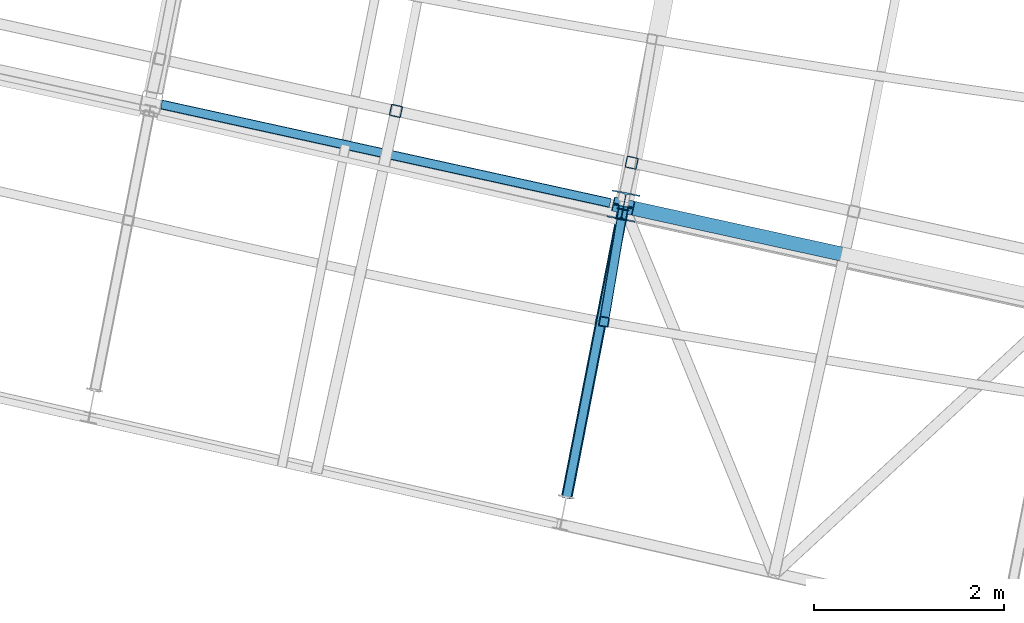
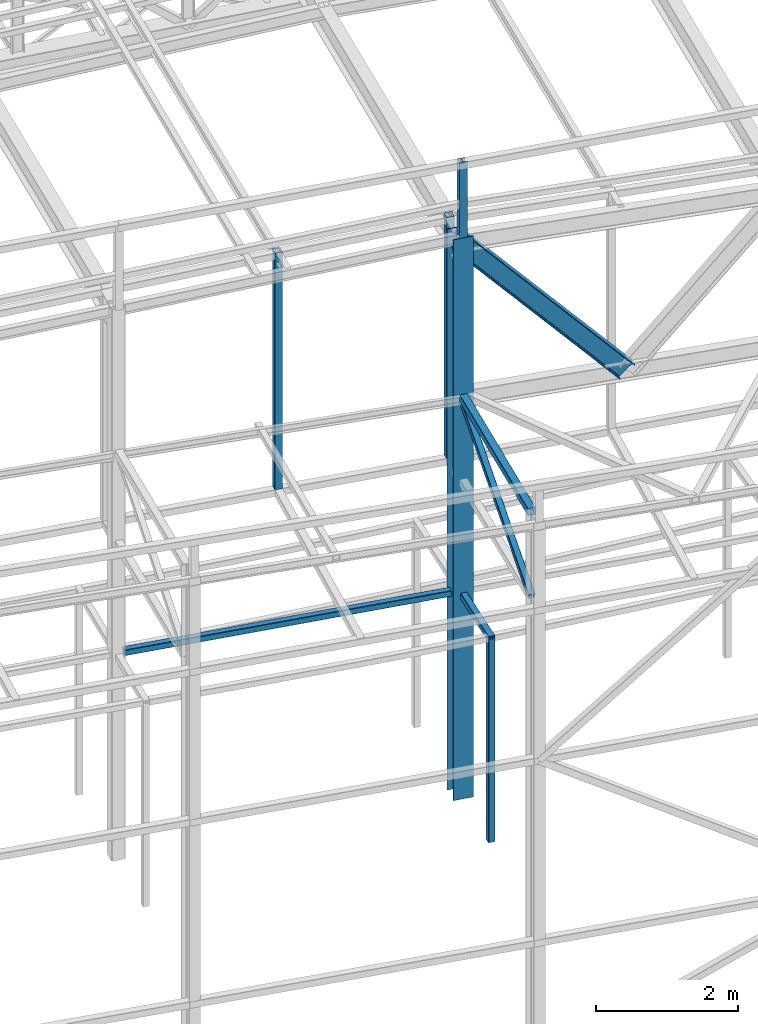
# One storey, part 30 of 215: 8 beams, 2 members, 10 elements without a shape of their own.
"""IFC2X3 building model written with IfcOpenShell, lengths in millimetres."""

from ifc_helpers import new_model, si_unit, frame, origin_with_axes, origin_2d_with_axis, place, context, subcontext, project, spatial, hollow_rectangle, i_section, extrude, clip, halfspace, material, type_object, element, aggregate, save


model = new_model("IFC2X3")

# Units and contexts
model_context = context("Model", 3, precision=1e-05, world=origin_with_axes())
body_context = subcontext(model_context, "Body", "Model", "MODEL_VIEW")
ifc_project = project(units=[si_unit("LENGTHUNIT", "METRE", prefix="MILLI"), si_unit("AREAUNIT", "SQUARE_METRE"), si_unit("VOLUMEUNIT", "CUBIC_METRE"), si_unit("MASSUNIT", "GRAM", prefix="KILO"), si_unit("TIMEUNIT", "SECOND"), si_unit("PLANEANGLEUNIT", "RADIAN"), si_unit("SOLIDANGLEUNIT", "STERADIAN"), si_unit("THERMODYNAMICTEMPERATUREUNIT", "DEGREE_CELSIUS"), si_unit("LUMINOUSINTENSITYUNIT", "LUMEN")], contexts=[model_context])

# Site, building, storey
site_placement = place(None, origin_with_axes())
site = spatial("IfcSite", under=ifc_project, at=site_placement, CompositionType="ELEMENT")
building_placement = place(site_placement, origin_with_axes())
building = spatial("IfcBuilding", under=site, at=building_placement, Name="Undefined", CompositionType="ELEMENT")
storey_placement = place(building_placement, origin_with_axes())
storey = spatial("IfcBuildingStorey", under=building, at=storey_placement, Name="Undefined", CompositionType="ELEMENT", Elevation=0.0)

# Assembly, beam
assembly_1_placement = place(storey_placement, origin_with_axes())
assembly_1 = element("IfcElementAssembly", 1, at=assembly_1_placement, inside=storey, Name="Steel Assembly", AssemblyPlace="NOTDEFINED", PredefinedType="RIGID_FRAME")
ifc_material = material(Name="STEEL/S275JR")
beam_type_1 = type_object("IfcBeamType", PredefinedType="NOTDEFINED")
beam_1_placement = place(assembly_1_placement, frame((59957.6958379519, 6918.37854954321, 6760.00000147687), z_axis=(0.214484663892396, 0.976727356509976, 0.0), x_axis=(0.976727356509977, -0.214484663892393, 0.0)))
beam_1 = element("IfcBeam", 2, at=beam_1_placement, type_object=beam_type_1, material=ifc_material, Name="POUTRE", context=body_context, shape_type="Clipping", body=[
    clip(clip(extrude(hollow_rectangle(XDim=100.0, YDim=100.0, WallThickness=4.0, InnerFilletRadius=4.0, OuterFilletRadius=8.0, at=origin_2d_with_axis()), frame((4983.42106291936, 0.0, 0.0), z_axis=(-1.0, 0.0, 0.0), x_axis=(-6.93889390390723e-18, -1.0, -3.46944695195361e-18)), (0.0, 0.0, 1.0), 4913.6), halfspace(frame((4945.47865223068, -50.0, -97.5978612047802), z_axis=(0.999733029085594, 0.0, 0.0231056390377605), x_axis=(-6.93889390390723e-18, -1.0, -3.46944695195361e-18)), False)), halfspace(frame((112.487861621019, -50.0, -108.588438077481), z_axis=(0.999733029085594, 0.0, 0.0231056390377605), x_axis=(-6.93889390390723e-18, -1.0, -3.46944695195361e-18)), True)),
])
aggregate(assembly_1, [beam_1])

assembly_2_placement = place(storey_placement, origin_with_axes())
assembly_2 = element("IfcElementAssembly", 3, at=assembly_2_placement, inside=storey, Name="Steel Assembly", AssemblyPlace="NOTDEFINED", PredefinedType="RIGID_FRAME")
beam_2_placement = place(assembly_2_placement, frame((64721.2626268386, 4609.40963025453, 6760.00000147429), z_axis=(-0.985956528905144, 0.167002164983933, 0.0), x_axis=(0.0, 0.0, -1.0)))
beam_2 = element("IfcBeam", 4, at=beam_2_placement, type_object=beam_type_1, material=ifc_material, Name="MONTANT", context=body_context, shape_type="SweptSolid", body=[
    extrude(hollow_rectangle(XDim=100.0, YDim=100.0, WallThickness=4.0, InnerFilletRadius=4.0, OuterFilletRadius=8.0, at=origin_2d_with_axis()), frame((3499.99999998675, 0.0, 0.0), z_axis=(-1.0, 0.0, 0.0), x_axis=(-6.93889390390723e-18, -1.0, -3.46944695195361e-18)), (0.0, 0.0, 1.0), 3500.0),
])
aggregate(assembly_2, [beam_2])

assembly_3_placement = place(storey_placement, origin_with_axes())
assembly_3 = element("IfcElementAssembly", 5, at=assembly_3_placement, inside=storey, Name="Steel Assembly", AssemblyPlace="NOTDEFINED", PredefinedType="RIGID_FRAME")
beam_3_placement = place(assembly_3_placement, frame((64712.9131716906, 4560.11566064499, 6760.00000147687), z_axis=(-0.985956528905144, 0.167002164983933, 0.0), x_axis=(0.16700243291904, 0.985956483522027, 0.0)))
beam_3 = element("IfcBeam", 6, at=beam_3_placement, type_object=beam_type_1, material=ifc_material, Name="POUTRE", context=body_context, shape_type="Clipping", body=[
    clip(extrude(hollow_rectangle(XDim=100.0, YDim=100.0, WallThickness=4.0, InnerFilletRadius=4.0, OuterFilletRadius=8.0, at=origin_2d_with_axis()), frame((1313.73837132465, 9.09494701772928e-13, 0.0), z_axis=(-1.0, 0.0, 0.0), x_axis=(-6.93889390390723e-18, -1.0, -3.46944695195361e-18)), (0.0, 0.0, 1.0), 1313.7), halfspace(frame((1277.35109839031, -49.9999999999991, -76.026027446278), z_axis=(0.999680784343529, 0.0, -0.025265181857768), x_axis=(-6.93889390390723e-18, -1.0, -3.46944695195361e-18)), False)),
])
aggregate(assembly_3, [beam_3])

assembly_4_placement = place(storey_placement, origin_with_axes())
assembly_4 = element("IfcElementAssembly", 7, at=assembly_4_placement, inside=storey, Name="Steel Assembly", AssemblyPlace="NOTDEFINED", PredefinedType="RIGID_FRAME")
beam_type_2 = type_object("IfcBeamType", PredefinedType="NOTDEFINED")
beam_4_placement = place(assembly_4_placement, frame((65011.7257418294, 6282.36539429258, 12919.9942183122), z_axis=(-0.214538758981639, -0.97671547591641, 0.0), x_axis=(0.0, 0.0, -1.0)))
beam_4 = element("IfcBeam", 8, at=beam_4_placement, type_object=beam_type_2, material=ifc_material, Name="LISSE", context=body_context, shape_type="SweptSolid", body=[
    extrude(hollow_rectangle(XDim=120.0, YDim=120.0, WallThickness=5.0, InnerFilletRadius=5.0, OuterFilletRadius=10.0, at=origin_2d_with_axis()), frame((4153.99340980045, 7.27595760043901e-12, 3.63797880741385e-12), z_axis=(-1.0, 0.0, 0.0), x_axis=(-6.93889390390723e-18, -1.0, -3.46944695195361e-18)), (0.0, 0.0, 1.0), 4154.0),
])
aggregate(assembly_4, [beam_4])

assembly_5_placement = place(storey_placement, origin_with_axes())
assembly_5 = element("IfcElementAssembly", 9, at=assembly_5_placement, inside=storey, Name="Steel Assembly", AssemblyPlace="NOTDEFINED", PredefinedType="RIGID_FRAME")
beam_5_placement = place(assembly_5_placement, frame((62531.8696883208, 6827.07470833983, 12838.673058891), z_axis=(-0.214538758981639, -0.97671547591641, 0.0), x_axis=(0.0, 0.0, -1.0)))
beam_5 = element("IfcBeam", 10, at=beam_5_placement, type_object=beam_type_2, material=ifc_material, Name="LISSE", context=body_context, shape_type="SweptSolid", body=[
    extrude(hollow_rectangle(XDim=120.0, YDim=120.0, WallThickness=5.0, InnerFilletRadius=5.0, OuterFilletRadius=10.0, at=origin_2d_with_axis()), frame((4072.67225026208, -1.3475342106798e-20, 3.63797880740754e-12), z_axis=(-1.0, 0.0, 0.0), x_axis=(-6.93889390390723e-18, -1.0, -3.46944695195361e-18)), (0.0, 0.0, 1.0), 4072.7),
])
aggregate(assembly_5, [beam_5])

assembly_6_placement = place(storey_placement, origin_with_axes())
assembly_6 = element("IfcElementAssembly", 11, at=assembly_6_placement, inside=storey, Name="Steel Assembly", AssemblyPlace="NOTDEFINED", PredefinedType="RIGID_FRAME")
beam_6_placement = place(assembly_6_placement, frame((64330.4991820635, 2772.96597174268, 10170.9408267938), z_axis=(-0.981422412140383, 0.191859451027444, 0.0), x_axis=(0.191859470081235, 0.981422408415534, 0.0)))
beam_6 = element("IfcBeam", 12, at=beam_6_placement, type_object=beam_type_2, material=ifc_material, context=body_context, shape_type="SweptSolid", body=[
    extrude(hollow_rectangle(XDim=120.0, YDim=120.0, WallThickness=5.0, InnerFilletRadius=5.0, OuterFilletRadius=10.0, at=origin_2d_with_axis()), frame((3110.43265503136, 0.0, 0.0), z_axis=(-1.0, 0.0, 0.0), x_axis=(-6.93889390390723e-18, -1.0, -3.46944695195361e-18)), (0.0, 0.0, 1.0), 3110.4),
])
aggregate(assembly_6, [beam_6])

# Assembly, member
assembly_7_placement = place(storey_placement, origin_with_axes())
assembly_7 = element("IfcElementAssembly", 13, at=assembly_7_placement, inside=storey, Name="Steel Assembly", AssemblyPlace="NOTDEFINED", PredefinedType="RIGID_FRAME")
member_type_1 = type_object("IfcMemberType", PredefinedType="NOTDEFINED")
member_1_placement = place(assembly_7_placement, frame((64927.2650798073, 5825.61429132215, 10171.6006128626), z_axis=(-0.981375695239557, 0.192097575046891, -0.00051619200012514), x_axis=(-0.173643948038074, -0.888243807194758, -0.425288982093249)))
member_1 = element("IfcMember", 14, at=member_1_placement, type_object=member_type_1, material=ifc_material, context=body_context, shape_type="SweptSolid", body=[
    extrude(hollow_rectangle(XDim=100.0, YDim=100.0, WallThickness=5.0, InnerFilletRadius=5.0, OuterFilletRadius=10.0, at=origin_2d_with_axis()), frame((3436.7233788912, 2.27373675443232e-13, 1.11037868018042e-13), z_axis=(-1.0, 0.0, 0.0), x_axis=(-6.93889390390723e-18, -1.0, -3.46944695195361e-18)), (0.0, 0.0, 1.0), 3436.7),
])
aggregate(assembly_7, [member_1])

# Assembly, beam
assembly_8_placement = place(storey_placement, origin_with_axes())
assembly_8 = element("IfcElementAssembly", 15, at=assembly_8_placement, inside=storey, Name="Steel Assembly", AssemblyPlace="NOTDEFINED", PredefinedType="RIGID_FRAME")
beam_type_3 = type_object("IfcBeamType", Name="HEA120", PredefinedType="NOTDEFINED")
beam_7_placement = place(assembly_8_placement, frame((64910.3168669649, 5739.2617465783, 14219.9969942338), z_axis=(0.191859470081235, 0.981422408415534, 0.0), x_axis=(0.0, 0.0, -1.0)))
beam_7 = element("IfcBeam", 16, at=beam_7_placement, type_object=beam_type_3, material=ifc_material, ObjectType="HEA120", context=body_context, shape_type="SweptSolid", body=[
    extrude(i_section(OverallWidth=120.0, OverallDepth=114.0, WebThickness=5.0, FlangeThickness=8.0, FilletRadius=12.0, at=origin_2d_with_axis()), frame((1302.28166085777, -6.73263838715565e-23, -2.69305535486226e-22), z_axis=(-1.0, 0.0, 0.0), x_axis=(-6.93889390390723e-18, -1.0, -3.46944695195361e-18)), (0.0, 0.0, 1.0), 1302.3),
])
aggregate(assembly_8, [beam_7])

assembly_9_placement = place(storey_placement, origin_with_axes())
assembly_9 = element("IfcElementAssembly", 17, at=assembly_9_placement, inside=storey, Name="Steel Assembly", AssemblyPlace="NOTDEFINED", PredefinedType="RIGID_FRAME")
beam_type_4 = type_object("IfcBeamType", Name="HEA300", PredefinedType="NOTDEFINED")
beam_8_placement = place(assembly_9_placement, frame((64927.2647284574, 5825.61436260759, 12917.7153332559), z_axis=(0.191859470081235, 0.981422408415534, 0.0), x_axis=(0.0, 0.0, -1.0)))
beam_8 = element("IfcBeam", 18, at=beam_8_placement, type_object=beam_type_4, material=ifc_material, Name="POTEAU", ObjectType="HEA300", context=body_context, shape_type="SweptSolid", body=[
    extrude(i_section(OverallWidth=300.0, OverallDepth=290.0, WebThickness=8.5, FlangeThickness=14.0, FilletRadius=27.0, at=origin_2d_with_axis()), frame((9657.71742338021, 0.0, 0.0), z_axis=(-1.0, 0.0, 0.0), x_axis=(-6.93889390390723e-18, -1.0, -3.46944695195361e-18)), (0.0, 0.0, 1.0), 9657.7),
])
aggregate(assembly_9, [beam_8])

# Assembly, member
assembly_10_placement = place(storey_placement, origin_with_axes())
assembly_10 = element("IfcElementAssembly", 19, at=assembly_10_placement, inside=storey, Name="Steel Assembly", AssemblyPlace="NOTDEFINED", PredefinedType="RIGID_FRAME")
member_type_2 = type_object("IfcMemberType", Name="IPE300", PredefinedType="NOTDEFINED")
member_2_placement = place(assembly_10_placement, frame((64922.7250033759, 5826.61229629808, 12769.8797269838), z_axis=(-0.726097319899024, 0.159611035977803, -0.66881013690699), x_axis=(0.653214322195451, -0.143589863042964, -0.743433252222444)))
member_2 = element("IfcMember", 20, at=member_2_placement, type_object=member_type_2, material=ifc_material, Name="POUTRE", ObjectType="IPE300", context=body_context, shape_type="SweptSolid", body=[
    extrude(i_section(OverallWidth=150.0, OverallDepth=300.0, WebThickness=7.099999905, FlangeThickness=10.69999981, FilletRadius=15.0, at=origin_2d_with_axis()), frame((3677.25777889146, -1.89365258145167e-14, -4.08257625360727e-13), z_axis=(-1.0, 0.0, 0.0), x_axis=(-6.93889390390723e-18, -1.0, -3.46944695195361e-18)), (0.0, 0.0, 1.0), 3677.3),
])
aggregate(assembly_10, [member_2])

save(model, "model.ifc")
